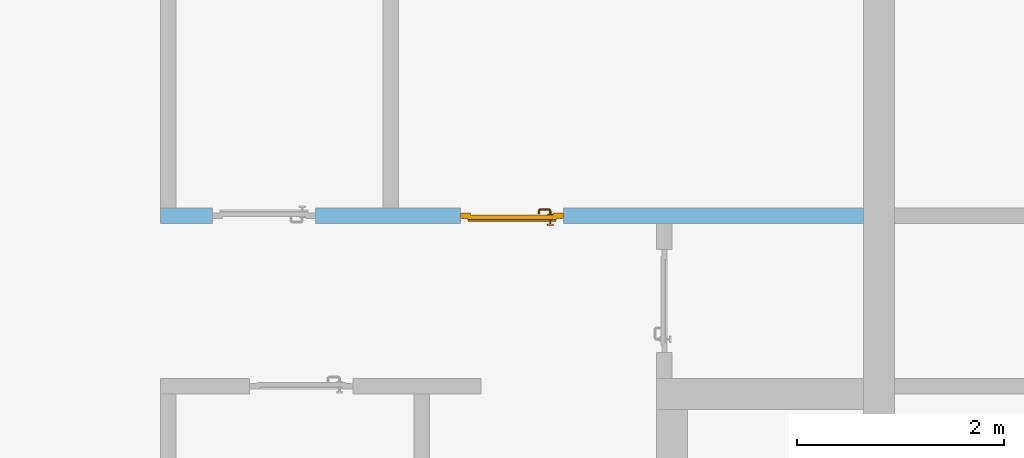
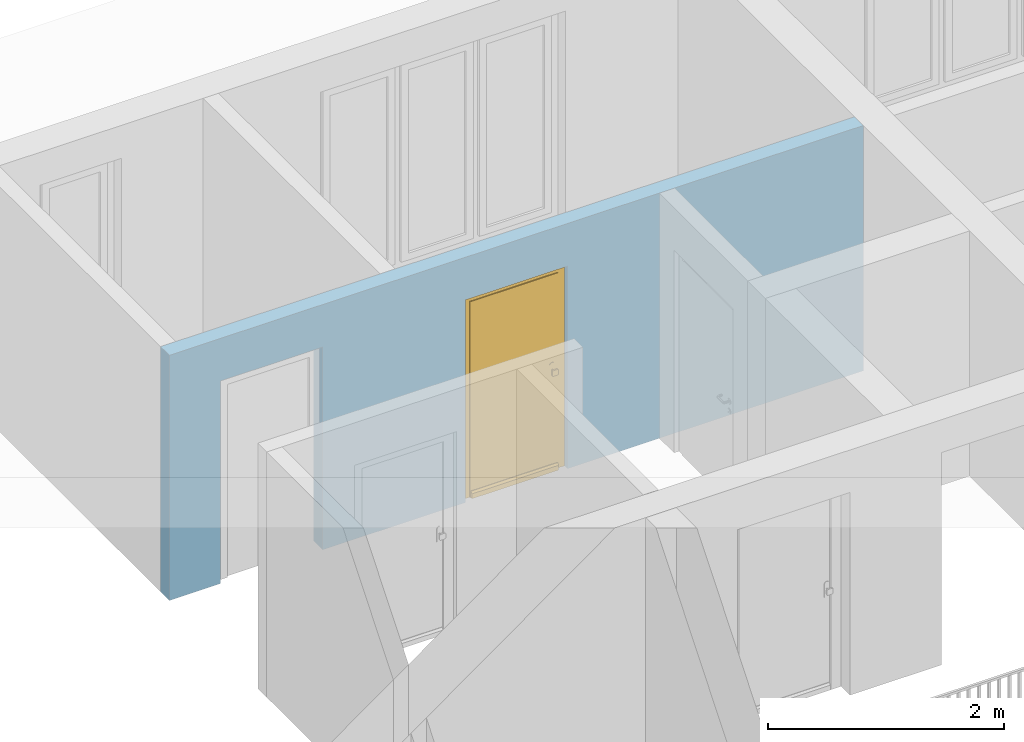
# One storey, part 26 of 54: 1 door, 2 openings, plus 1 element that does not belong to this part.
"""IFC4 building model written with IfcOpenShell, lengths in metres."""

from ifc_helpers import new_model, entity, si_unit, converted_unit, derived_unit, direction, frame, origin_with_axes, place, context, subcontext, project, spatial, polygons, source, transform, mapped, material, type_object, element, fill, save


model = new_model("IFC4")

# Units and contexts
model_context = context("Model", 3, precision=1e-05, world=origin_with_axes(), true_north=direction((0.0, 1.0)))
body_context = subcontext(model_context, "Body", "Model", "MODEL_VIEW")
ifc_project = project(units=[si_unit("LENGTHUNIT", "METRE"), si_unit("AREAUNIT", "SQUARE_METRE"), si_unit("VOLUMEUNIT", "CUBIC_METRE"), converted_unit("PLANEANGLEUNIT", "DEGREE", entity("IfcPlaneAngleMeasure", 0.0174532925199), si_unit("PLANEANGLEUNIT", "RADIAN"), dimensions=[0, 0, 0, 0, 0, 0, 0]), converted_unit("TIMEUNIT", "Year", entity("IfcTimeMeasure", 31556926.0), si_unit("TIMEUNIT", "SECOND"), dimensions=[0, 0, 1, 0, 0, 0, 0]), si_unit("MASSUNIT", "GRAM", prefix="KILO"), si_unit("THERMODYNAMICTEMPERATUREUNIT", "DEGREE_CELSIUS"), si_unit("LUMINOUSINTENSITYUNIT", "LUMEN"), si_unit("ENERGYUNIT", "JOULE", prefix="MEGA"), derived_unit("THERMALCONDUCTANCEUNIT", [(si_unit("POWERUNIT", "WATT"), 1), (si_unit("LENGTHUNIT", "METRE"), -1), (si_unit("THERMODYNAMICTEMPERATUREUNIT", "KELVIN"), -1)]), derived_unit("SPECIFICHEATCAPACITYUNIT", [(si_unit("ENERGYUNIT", "JOULE"), 1), (si_unit("MASSUNIT", "GRAM", prefix="KILO"), -1), (si_unit("THERMODYNAMICTEMPERATUREUNIT", "KELVIN"), -1)]), derived_unit("MASSDENSITYUNIT", [(si_unit("MASSUNIT", "GRAM", prefix="KILO"), 1), (si_unit("VOLUMEUNIT", "CUBIC_METRE"), -1)])], contexts=[model_context])

# Site, building, storey
site_placement = place(None, origin_with_axes())
site = spatial("IfcSite", under=ifc_project, at=site_placement, CompositionType="ELEMENT")
building_placement = place(site_placement, origin_with_axes())
building = spatial("IfcBuilding", under=site, at=building_placement, CompositionType="ELEMENT")
storey_placement = place(building_placement, frame((0.0, 0.0, 9.18), z_axis=(0.0, 0.0, 1.0), x_axis=(1.0, 0.0, 0.0)))
storey = spatial("IfcBuildingStorey", under=building, at=storey_placement, Name="3. Geschoss", CompositionType="ELEMENT", Elevation=9.18)

# Wall, openings, door
ifc_material = material()
wall_type = type_object("IfcWallType", Name="150", PredefinedType="NOTDEFINED")
wall_placement = place(storey_placement, frame((-7.5421993804, 5.47118776896, 0.0), z_axis=(0.0, 0.0, 1.0), x_axis=(1.0, 0.0, 0.0)))
wall = element("IfcWall", 1, at=wall_placement, inside=storey, type_object=wall_type, material=ifc_material, Name="Wand-002", PredefinedType="NOTDEFINED", context=body_context, shape_type="Tessellation", body=[
    polygons([(2.9, 0.15, 2.1), (2.9, 0.15, 0.0), (1.5, 0.15, 0.0), (1.5, 0.15, 2.1), (0.5, 0.15, 2.1), (0.5, 0.15, 0.0), (0.0, 0.15, 0.0), (0.0, 0.15, 2.54), (6.8, 0.15, 2.54), (6.8, 0.15, 0.0), (3.9, 0.15, 0.0), (3.9, 0.15, 2.1), (2.9, 0.05, 2.1), (2.9, 0.05, 0.0), (2.9, 0.0, 0.0), (1.5, 0.0, 0.0), (1.5, 0.1, 0.0), (1.5, 0.1, 2.1), (0.5, 0.1, 2.1), (0.5, 0.1, 0.0), (0.5, 0.0, 0.0), (0.0, 0.0, 0.0), (0.0, 0.0, 2.54), (6.8, 0.0, 2.54), (6.8, 0.0, 0.0), (3.9, 0.05, 0.0), (3.9, 0.0, 0.0), (3.9, 0.05, 2.1), (2.9, 0.0, 2.1), (3.9, 0.0, 2.1), (0.5, 0.0, 2.1), (1.5, 0.0, 2.1)], [[[1, 2, 3, 4, 5, 6, 7, 8, 9, 10, 11, 12]], [[2, 1, 13, 14]], [[2, 14, 15, 16, 17, 3]], [[4, 3, 17, 18]], [[5, 4, 18, 19]], [[6, 5, 19, 20]], [[6, 20, 21, 22, 7]], [[22, 23, 8, 7]], [[23, 24, 9, 8]], [[10, 9, 24, 25]], [[26, 11, 10, 25, 27]], [[12, 11, 26, 28]], [[1, 12, 28, 13]], [[14, 13, 29, 15]], [[16, 15, 29, 30, 27, 25, 24, 23, 22, 21, 31, 32]], [[16, 32, 18, 17]], [[32, 31, 19, 18]], [[31, 21, 20, 19]], [[28, 26, 27, 30]], [[13, 28, 30, 29]]], closed=True),
])
opening_1_placement = place(wall_placement, frame((1.0, 0.0, 0.0), z_axis=(0.0, 0.0, 1.0), x_axis=(1.0, 0.0, 0.0)))
element("IfcOpeningElement", 2, at=opening_1_placement, cuts=wall, context=body_context, identifier="Reference", shape_type="Tessellation", body=[
    polygons([(-0.5, 0.1, 0.0), (-0.5, 0.1, 2.1), (-0.5, 0.151, 2.1), (-0.5, 0.151, 0.0), (-0.5, -0.001, 0.0), (-0.5, -0.001, 2.1), (0.5, 0.1, 2.1), (0.5, 0.151, 2.1), (0.5, -0.001, 2.1), (0.5, 0.151, 0.0), (0.5, 0.1, 0.0), (0.5, -0.001, 0.0)], [[[1, 2, 3, 4]], [[2, 1, 5, 6]], [[7, 8, 3, 2, 6, 9]], [[8, 10, 4, 3]], [[1, 4, 10, 11, 12, 5]], [[6, 5, 12, 9]], [[7, 11, 10, 8]], [[11, 7, 9, 12]]], closed=True),
])
opening_2_placement = place(wall_placement, frame((3.4, 0.0, 0.0), z_axis=(0.0, 0.0, 1.0), x_axis=(1.0, 0.0, 0.0)))
opening_2 = element("IfcOpeningElement", 3, at=opening_2_placement, cuts=wall, context=body_context, identifier="Reference", shape_type="Tessellation", body=[
    polygons([(0.5, 0.05, 0.0), (0.5, 0.05, 2.1), (0.5, -0.001, 2.1), (0.5, -0.001, 0.0), (0.5, 0.151, 0.0), (0.5, 0.151, 2.1), (-0.5, 0.05, 2.1), (-0.5, -0.001, 2.1), (-0.5, 0.151, 2.1), (-0.5, -0.001, 0.0), (-0.5, 0.05, 0.0), (-0.5, 0.151, 0.0)], [[[1, 2, 3, 4]], [[2, 1, 5, 6]], [[7, 8, 3, 2, 6, 9]], [[8, 10, 4, 3]], [[1, 4, 10, 11, 12, 5]], [[6, 5, 12, 9]], [[7, 11, 10, 8]], [[11, 7, 9, 12]]], closed=True),
])
door_type = type_object("IfcDoorType", Name="Eingang 01 1-Fl 26", OperationType="SINGLE_SWING_RIGHT", PredefinedType="DOOR")
shared_shape = source(origin_with_axes(), body_context, "Body", "Tessellation", [
    polygons([(0.5, -0.05, 0.0), (0.5, -0.03, 0.0), (0.5, -0.03, 2.1), (0.5, -0.05, 2.1), (0.4, -0.05, 0.0), (0.4, -0.03, 0.0), (0.4, -0.03, 2.0), (0.1301, -0.03, 2.0), (0.0001, -0.03, 2.0), (-0.4, -0.03, 2.0), (-0.4, -0.03, 0.0), (-0.5, -0.03, 0.0), (-0.5, -0.03, 2.1), (-0.5, -0.05, 2.1), (-0.5, -0.05, 0.0), (-0.4, -0.05, 0.0), (-0.4, -0.05, 2.0), (0.0001, -0.05, 2.0), (0.1301, -0.05, 2.0), (0.4, -0.05, 2.0)], [[[1, 2, 3, 4]], [[5, 6, 2, 1]], [[2, 6, 7, 8, 9, 10, 11, 12, 13, 3]], [[4, 3, 13, 14]], [[1, 4, 14, 15, 16, 17, 18, 19, 20, 5]], [[20, 7, 6, 5]], [[19, 8, 7, 20]], [[18, 9, 8, 19]], [[17, 10, 9, 18]], [[16, 11, 10, 17]], [[15, 12, 11, 16]], [[14, 13, 12, 15]]], closed=True),
    polygons([(0.5, -0.03, 0.0), (0.5, 0.0, 0.0), (0.5, 0.0, 2.1), (0.5, -0.03, 2.1), (0.43, -0.03, 0.0), (0.43, 0.0, 0.0), (0.43, 0.0, 2.03), (0.1001, 0.0, 2.03), (0.0301, 0.0, 2.03), (-0.43, 0.0, 2.03), (-0.43, 0.0, 0.0), (-0.5, 0.0, 0.0), (-0.5, 0.0, 2.1), (-0.5, -0.03, 2.1), (-0.5, -0.03, 0.0), (-0.43, -0.03, 0.0), (-0.43, -0.03, 2.03), (0.0301, -0.03, 2.03), (0.1001, -0.03, 2.03), (0.43, -0.03, 2.03)], [[[1, 2, 3, 4]], [[5, 6, 2, 1]], [[2, 6, 7, 8, 9, 10, 11, 12, 13, 3]], [[4, 3, 13, 14]], [[1, 4, 14, 15, 16, 17, 18, 19, 20, 5]], [[20, 7, 6, 5]], [[19, 8, 7, 20]], [[18, 9, 8, 19]], [[17, 10, 9, 18]], [[16, 11, 10, 17]], [[15, 12, 11, 16]], [[14, 13, 12, 15]]], closed=True),
    polygons([(0.43, 0.01, 0.0), (-0.43, 0.01, 0.0), (-0.43, 0.01, 2.03), (0.43, 0.01, 2.03), (0.43, -0.03, 0.0), (-0.43, -0.03, 0.0), (-0.43, -0.03, 2.03), (0.43, -0.03, 2.03)], [[[1, 2, 3, 4]], [[2, 1, 5, 6]], [[3, 2, 6, 7]], [[4, 3, 7, 8]], [[1, 4, 8, 5]], [[6, 5, 8, 7]]], closed=True),
    polygons([(0.425, 0.03, 0.0), (-0.425, 0.03, 0.0), (-0.425, 0.03, 0.05), (0.425, 0.03, 0.05), (0.425, 0.01, 0.0), (-0.425, 0.01, 0.0), (-0.425, 0.01, 0.07), (-0.425, 0.015, 0.07), (0.425, 0.015, 0.07), (0.425, 0.01, 0.07)], [[[1, 2, 3, 4]], [[5, 6, 2, 1]], [[2, 6, 7, 8, 3]], [[4, 3, 8, 9]], [[1, 4, 9, 10, 5]], [[10, 7, 6, 5]], [[9, 8, 7, 10]]], closed=True),
    polygons([(-0.3835, -0.04, 1.0733826859), (-0.37, -0.04, 1.077), (-0.37, -0.0399, 1.077), (-0.3835, -0.0399, 1.0733826859), (-0.393382685902, -0.04, 1.0635), (-0.397, -0.04, 1.05), (-0.393382685902, -0.04, 1.0365), (-0.3835, -0.04, 1.0266173141), (-0.37, -0.04, 1.023), (-0.3565, -0.04, 1.0266173141), (-0.346617314098, -0.04, 1.0365), (-0.343, -0.04, 1.05), (-0.346617314098, -0.04, 1.0635), (-0.3565, -0.04, 1.0733826859), (-0.3565, -0.0399, 1.0733826859), (-0.37, -0.0301, 1.077), (-0.3835, -0.0301, 1.0733826859), (-0.393382685902, -0.0399, 1.0635), (-0.397, -0.0399, 1.05), (-0.393382685902, -0.0399, 1.0365), (-0.3835, -0.0399, 1.0266173141), (-0.37, -0.0399, 1.023), (-0.3565, -0.0399, 1.0266173141), (-0.346617314098, -0.0399, 1.0365), (-0.343, -0.0399, 1.05), (-0.346617314098, -0.0399, 1.0635), (-0.3565, -0.0301, 1.0733826859), (-0.37, -0.03, 1.077), (-0.3835, -0.03, 1.0733826859), (-0.393382685902, -0.0301, 1.0635), (-0.397, -0.0301, 1.05), (-0.393382685902, -0.0301, 1.0365), (-0.3835, -0.0301, 1.0266173141), (-0.37, -0.0301, 1.023), (-0.3565, -0.0301, 1.0266173141), (-0.346617314098, -0.0301, 1.0365), (-0.343, -0.0301, 1.05), (-0.346617314098, -0.0301, 1.0635), (-0.3565, -0.03, 1.0733826859), (-0.346617314098, -0.03, 1.0635), (-0.343, -0.03, 1.05), (-0.346617314098, -0.03, 1.0365), (-0.3565, -0.03, 1.0266173141), (-0.37, -0.03, 1.023), (-0.3835, -0.03, 1.0266173141), (-0.393382685902, -0.03, 1.0365), (-0.397, -0.03, 1.05), (-0.393382685902, -0.03, 1.0635)], [[[1, 2, 3, 4]], [[2, 1, 5, 6, 7, 8, 9, 10, 11, 12, 13, 14]], [[2, 14, 15, 3]], [[4, 3, 16, 17]], [[5, 1, 4, 18]], [[6, 5, 18, 19]], [[7, 6, 19, 20]], [[8, 7, 20, 21]], [[9, 8, 21, 22]], [[10, 9, 22, 23]], [[11, 10, 23, 24]], [[12, 11, 24, 25]], [[13, 12, 25, 26]], [[14, 13, 26, 15]], [[3, 15, 27, 16]], [[17, 16, 28, 29]], [[18, 4, 17, 30]], [[19, 18, 30, 31]], [[20, 19, 31, 32]], [[21, 20, 32, 33]], [[22, 21, 33, 34]], [[23, 22, 34, 35]], [[24, 23, 35, 36]], [[25, 24, 36, 37]], [[26, 25, 37, 38]], [[15, 26, 38, 27]], [[16, 27, 39, 28]], [[28, 39, 40, 41, 42, 43, 44, 45, 46, 47, 48, 29]], [[30, 17, 29, 48]], [[31, 30, 48, 47]], [[32, 31, 47, 46]], [[33, 32, 46, 45]], [[34, 33, 45, 44]], [[35, 34, 44, 43]], [[36, 35, 43, 42]], [[37, 36, 42, 41]], [[38, 37, 41, 40]], [[27, 38, 40, 39]]], closed=True),
    polygons([(-0.362532169224, -0.04, 0.959692280177), (-0.365, -0.04, 0.9544), (-0.365, -0.04, 0.952886751346), (-0.346703916638, -0.04, 0.96345), (-0.35655, -0.04, 0.973296083362), (-0.363279754556, -0.04, 0.961639806549), (-0.362532169224, -0.039, 0.959692280177), (-0.365, -0.039, 0.9544), (-0.365, -0.039, 0.952886751346), (-0.365, -0.039, 0.95), (-0.365, -0.039, 0.947113248654), (-0.365, -0.039, 0.941339745962), (-0.365, -0.039, 0.9375), (-0.365, -0.04, 0.9375), (-0.365, -0.04, 0.941339745962), (-0.365, -0.04, 0.947113248654), (-0.365, -0.04, 0.95), (-0.3431, -0.04, 0.95), (-0.346617314098, -0.04, 0.9635), (-0.3565, -0.04, 0.973382685902), (-0.364624817685, -0.04, 0.965143815798), (-0.37, -0.04, 0.9769), (-0.37, -0.04, 0.967425445323), (-0.364624817685, -0.039, 0.965143815798), (-0.363279754556, -0.039, 0.961639806549), (-0.35705, -0.039, 0.972430057958), (-0.347569942042, -0.039, 0.96295), (-0.3441, -0.039, 0.95), (-0.347569942042, -0.039, 0.93705), (-0.35705, -0.039, 0.927569942042), (-0.37, -0.039, 0.9241), (-0.37, -0.039, 0.9325), (-0.366464466094, -0.039, 0.933964466094), (-0.366464466094, -0.04, 0.933964466094), (-0.35655, -0.04, 0.926703916638), (-0.37, -0.04, 0.9325), (-0.37, -0.04, 0.9231), (-0.346703916638, -0.04, 0.93655), (-0.343, -0.04, 0.95), (-0.346617314098, -0.0399, 0.9635), (-0.3565, -0.0399, 0.973382685902), (-0.37, -0.04, 0.977), (-0.375375182315, -0.04, 0.965143815798), (-0.38345, -0.04, 0.973296083362), (-0.376720245444, -0.04, 0.961639806549), (-0.37, -0.039, 0.967425445323), (-0.37, -0.039, 0.9759), (-0.357, -0.039, 0.972516660498), (-0.347483339502, -0.039, 0.963), (-0.344, -0.039, 0.95), (-0.347483339502, -0.039, 0.937), (-0.357, -0.039, 0.927483339502), (-0.38295, -0.039, 0.927569942042), (-0.375, -0.039, 0.941339745962), (-0.375, -0.039, 0.9375), (-0.373535533906, -0.039, 0.933964466094), (-0.37, -0.039, 0.924), (-0.373535533906, -0.04, 0.933964466094), (-0.375, -0.04, 0.9375), (-0.375, -0.04, 0.941339745962), (-0.38345, -0.04, 0.926703916638), (-0.37, -0.04, 0.923), (-0.3565, -0.04, 0.926617314098), (-0.346617314098, -0.04, 0.9365), (-0.343, -0.0399, 0.95), (-0.346617314098, -0.0301, 0.9635), (-0.3565, -0.0301, 0.973382685902), (-0.37, -0.0399, 0.977), (-0.3835, -0.04, 0.973382685902), (-0.375375182315, -0.039, 0.965143815798), (-0.377467830776, -0.04, 0.959692280177), (-0.393296083362, -0.04, 0.96345), (-0.375, -0.04, 0.952886751346), (-0.375, -0.04, 0.9544), (-0.377467830776, -0.039, 0.959692280177), (-0.376720245444, -0.039, 0.961639806549), (-0.38295, -0.039, 0.972430057958), (-0.37, -0.039, 0.976), (-0.357, -0.0389, 0.972516660498), (-0.347483339502, -0.0389, 0.963), (-0.344, -0.0389, 0.95), (-0.347483339502, -0.0389, 0.937), (-0.357, -0.0389, 0.927483339502), (-0.392430057958, -0.039, 0.93705), (-0.375, -0.039, 0.947113248654), (-0.375, -0.039, 0.9544), (-0.375, -0.04, 0.95), (-0.375, -0.04, 0.947113248654), (-0.375, -0.039, 0.95), (-0.375, -0.039, 0.952886751346), (-0.383, -0.039, 0.927483339502), (-0.37, -0.0389, 0.924), (-0.393296083362, -0.04, 0.93655), (-0.3835, -0.04, 0.926617314098), (-0.37, -0.0399, 0.923), (-0.3565, -0.0399, 0.926617314098), (-0.346617314098, -0.0399, 0.9365), (-0.343, -0.0301, 0.95), (-0.346617314098, -0.03, 0.9635), (-0.3565, -0.03, 0.973382685902), (-0.37, -0.0301, 0.977), (-0.3835, -0.0399, 0.973382685902), (-0.393382685902, -0.04, 0.9635), (-0.3969, -0.04, 0.95), (-0.392430057958, -0.039, 0.96295), (-0.383, -0.039, 0.972516660498), (-0.37, -0.0389, 0.976), (-0.357, -0.0301, 0.972516660498), (-0.347483339502, -0.0301, 0.963), (-0.344, -0.0301, 0.95), (-0.347483339502, -0.0301, 0.937), (-0.357, -0.0301, 0.927483339502), (-0.392516660498, -0.039, 0.937), (-0.3959, -0.039, 0.95), (-0.383, -0.0389, 0.927483339502), (-0.37, -0.0301, 0.924), (-0.393382685902, -0.04, 0.9365), (-0.3835, -0.0399, 0.926617314098), (-0.37, -0.0301, 0.923), (-0.3565, -0.0301, 0.926617314098), (-0.346617314098, -0.0301, 0.9365), (-0.343, -0.03, 0.95), (-0.346703916638, -0.03, 0.96345), (-0.35655, -0.03, 0.973296083362), (-0.37, -0.03, 0.977), (-0.3835, -0.0301, 0.973382685902), (-0.393382685902, -0.0399, 0.9635), (-0.397, -0.04, 0.95), (-0.392516660498, -0.039, 0.963), (-0.383, -0.0389, 0.972516660498), (-0.37, -0.0301, 0.976), (-0.357, -0.03, 0.972516660498), (-0.347483339502, -0.03, 0.963), (-0.344, -0.03, 0.95), (-0.347483339502, -0.03, 0.937), (-0.357, -0.03, 0.927483339502), (-0.392516660498, -0.0389, 0.937), (-0.396, -0.039, 0.95), (-0.383, -0.0301, 0.927483339502), (-0.37, -0.03, 0.924), (-0.393382685902, -0.0399, 0.9365), (-0.3835, -0.0301, 0.926617314098), (-0.37, -0.03, 0.923), (-0.3565, -0.03, 0.926617314098), (-0.346617314098, -0.03, 0.9365), (-0.3431, -0.03, 0.95), (-0.347396736961, -0.03, 0.96305), (-0.35695, -0.03, 0.972603263039), (-0.37, -0.03, 0.9769), (-0.3835, -0.03, 0.973382685902), (-0.393382685902, -0.0301, 0.9635), (-0.397, -0.0399, 0.95), (-0.392516660498, -0.0389, 0.963), (-0.383, -0.0301, 0.972516660498), (-0.37, -0.03, 0.976), (-0.3439, -0.03, 0.95), (-0.347396736961, -0.03, 0.93695), (-0.35695, -0.03, 0.927396736961), (-0.392516660498, -0.0301, 0.937), (-0.396, -0.0389, 0.95), (-0.383, -0.03, 0.927483339502), (-0.37, -0.03, 0.9239), (-0.393382685902, -0.0301, 0.9365), (-0.3835, -0.03, 0.926617314098), (-0.37, -0.03, 0.9231), (-0.35655, -0.03, 0.926703916638), (-0.346703916638, -0.03, 0.93655), (-0.37, -0.03, 0.9761), (-0.38345, -0.03, 0.973296083362), (-0.393382685902, -0.03, 0.9635), (-0.397, -0.0301, 0.95), (-0.392516660498, -0.0301, 0.963), (-0.383, -0.03, 0.972516660498), (-0.392516660498, -0.03, 0.937), (-0.396, -0.0301, 0.95), (-0.38305, -0.03, 0.927396736961), (-0.393382685902, -0.03, 0.9365), (-0.38345, -0.03, 0.926703916638), (-0.38305, -0.03, 0.972603263039), (-0.393296083362, -0.03, 0.96345), (-0.397, -0.03, 0.95), (-0.392516660498, -0.03, 0.963), (-0.392603263039, -0.03, 0.93695), (-0.396, -0.03, 0.95), (-0.393296083362, -0.03, 0.93655), (-0.392603263039, -0.03, 0.96305), (-0.3969, -0.03, 0.95), (-0.3961, -0.03, 0.95)], [[[1, 2, 3, 4, 5, 6]], [[2, 1, 7, 8]], [[2, 8, 9, 10, 11, 12, 13, 14, 15, 16, 17, 3]], [[17, 18, 4, 3]], [[19, 20, 5, 4]], [[21, 6, 5, 22, 23]], [[1, 6, 21, 24, 25, 7]], [[7, 25, 26, 27, 9, 8]], [[9, 27, 28, 10]], [[10, 28, 29, 11]], [[11, 29, 30, 12]], [[31, 32, 33, 13, 12, 30]], [[14, 13, 33, 34]], [[35, 15, 14, 34, 36, 37]], [[15, 35, 38, 16]], [[16, 38, 18, 17]], [[39, 19, 4, 18]], [[40, 41, 20, 19]], [[20, 42, 22, 5]], [[43, 23, 22, 44, 45]], [[21, 23, 46, 24]], [[24, 46, 47, 26, 25]], [[27, 26, 48, 49]], [[28, 27, 49, 50]], [[29, 28, 50, 51]], [[30, 29, 51, 52]], [[53, 54, 55, 56, 32, 31]], [[34, 33, 32, 36]], [[31, 30, 52, 57]], [[37, 36, 58, 59, 60, 61]], [[62, 63, 35, 37]], [[63, 64, 38, 35]], [[64, 39, 18, 38]], [[65, 40, 19, 39]], [[66, 67, 41, 40]], [[41, 68, 42, 20]], [[42, 69, 44, 22]], [[23, 43, 70, 46]], [[71, 45, 44, 72, 73, 74]], [[43, 45, 71, 75, 76, 70]], [[70, 76, 77, 47, 46]], [[26, 47, 78, 48]], [[49, 48, 79, 80]], [[50, 49, 80, 81]], [[51, 50, 81, 82]], [[52, 51, 82, 83]], [[54, 53, 84, 85]], [[86, 74, 73, 87, 88, 60, 59, 55, 54, 85, 89, 90]], [[58, 56, 55, 59]], [[36, 32, 56, 58]], [[53, 31, 57, 91]], [[57, 52, 83, 92]], [[88, 93, 61, 60]], [[94, 62, 37, 61]], [[95, 96, 63, 62]], [[96, 97, 64, 63]], [[97, 65, 39, 64]], [[98, 66, 40, 65]], [[99, 100, 67, 66]], [[67, 101, 68, 41]], [[68, 102, 69, 42]], [[69, 103, 72, 44]], [[73, 72, 104, 87]], [[71, 74, 86, 75]], [[75, 86, 90, 105, 77, 76]], [[47, 77, 106, 78]], [[48, 78, 107, 79]], [[80, 79, 108, 109]], [[81, 80, 109, 110]], [[82, 81, 110, 111]], [[83, 82, 111, 112]], [[84, 53, 91, 113]], [[85, 84, 114, 89]], [[87, 104, 93, 88]], [[89, 114, 105, 90]], [[91, 57, 92, 115]], [[92, 83, 112, 116]], [[117, 94, 61, 93]], [[118, 95, 62, 94]], [[119, 120, 96, 95]], [[120, 121, 97, 96]], [[121, 98, 65, 97]], [[122, 99, 66, 98]], [[123, 124, 100, 99]], [[100, 125, 101, 67]], [[101, 126, 102, 68]], [[102, 127, 103, 69]], [[103, 128, 104, 72]], [[77, 105, 129, 106]], [[78, 106, 130, 107]], [[79, 107, 131, 108]], [[109, 108, 132, 133]], [[110, 109, 133, 134]], [[111, 110, 134, 135]], [[112, 111, 135, 136]], [[113, 91, 115, 137]], [[114, 84, 113, 138]], [[128, 117, 93, 104]], [[105, 114, 138, 129]], [[115, 92, 116, 139]], [[116, 112, 136, 140]], [[141, 118, 94, 117]], [[142, 119, 95, 118]], [[143, 144, 120, 119]], [[144, 145, 121, 120]], [[145, 122, 98, 121]], [[146, 123, 99, 122]], [[147, 148, 124, 123]], [[124, 149, 125, 100]], [[125, 150, 126, 101]], [[126, 151, 127, 102]], [[127, 152, 128, 103]], [[106, 129, 153, 130]], [[107, 130, 154, 131]], [[108, 131, 155, 132]], [[133, 132, 148, 147]], [[134, 133, 147, 156]], [[135, 134, 156, 157]], [[136, 135, 157, 158]], [[137, 115, 139, 159]], [[138, 113, 137, 160]], [[152, 141, 117, 128]], [[129, 138, 160, 153]], [[139, 116, 140, 161]], [[140, 136, 158, 162]], [[163, 142, 118, 141]], [[164, 143, 119, 142]], [[165, 166, 144, 143]], [[166, 167, 145, 144]], [[167, 146, 122, 145]], [[156, 147, 123, 146]], [[148, 168, 149, 124]], [[149, 169, 150, 125]], [[150, 170, 151, 126]], [[151, 171, 152, 127]], [[130, 153, 172, 154]], [[131, 154, 173, 155]], [[132, 155, 168, 148]], [[157, 156, 146, 167]], [[158, 157, 167, 166]], [[159, 139, 161, 174]], [[160, 137, 159, 175]], [[171, 163, 141, 152]], [[153, 160, 175, 172]], [[161, 140, 162, 176]], [[162, 158, 166, 165]], [[177, 164, 142, 163]], [[178, 165, 143, 164]], [[168, 179, 169, 149]], [[169, 180, 170, 150]], [[170, 181, 171, 151]], [[154, 172, 182, 173]], [[155, 173, 179, 168]], [[174, 161, 176, 183]], [[175, 159, 174, 184]], [[181, 177, 163, 171]], [[172, 175, 184, 182]], [[176, 162, 165, 178]], [[185, 178, 164, 177]], [[179, 186, 180, 169]], [[180, 187, 181, 170]], [[173, 182, 186, 179]], [[183, 176, 178, 185]], [[184, 174, 183, 188]], [[187, 185, 177, 181]], [[182, 184, 188, 186]], [[186, 188, 187, 180]], [[188, 183, 185, 187]]], closed=True),
    polygons([(-0.38, -0.04, 1.05), (-0.377071067812, -0.04, 1.04292893219), (-0.377071067812, -0.070696439392, 1.04292893219), (-0.38, -0.0709849140336, 1.05), (-0.37, -0.04, 1.04), (-0.37, -0.07, 1.04), (-0.375518993221, -0.0784992452783, 1.04292893219), (-0.378277987014, -0.0796420579258, 1.05), (-0.377071067812, -0.04, 1.05707106781), (-0.377071067812, -0.070696439392, 1.05707106781), (-0.362928932188, -0.04, 1.04292893219), (-0.362928932188, -0.069303560608, 1.04292893219), (-0.368858192988, -0.0757402514855, 1.04), (-0.370704557509, -0.0857045575088, 1.04292893219), (-0.372816199938, -0.0878161999379, 1.05), (-0.375518993221, -0.0784992452783, 1.05707106781), (-0.37, -0.04, 1.06), (-0.37, -0.07, 1.06), (-0.36, -0.04, 1.05), (-0.36, -0.0690150859664, 1.05), (-0.362197392755, -0.0729812576926, 1.04292893219), (-0.365606601718, -0.0806066017178, 1.04), (-0.363499245278, -0.0905189932208, 1.04292893219), (-0.364642057926, -0.0932779870137, 1.05), (-0.370704557509, -0.0857045575088, 1.05707106781), (-0.368858192988, -0.0757402514855, 1.06), (-0.362928932188, -0.04, 1.05707106781), (-0.362928932188, -0.069303560608, 1.05707106781), (-0.359438398962, -0.0718384450452, 1.05), (-0.360508645927, -0.0755086459268, 1.04292893219), (-0.360740251485, -0.0838581929877, 1.04), (-0.355696439392, -0.0920710678119, 1.04292893219), (-0.355984914034, -0.095, 1.05), (-0.363499245278, -0.0905189932208, 1.05707106781), (-0.365606601718, -0.0806066017178, 1.06), (-0.362197392755, -0.0729812576926, 1.05707106781), (-0.358397003498, -0.0733970034977, 1.05), (-0.357981257693, -0.0771973927545, 1.04292893219), (-0.355, -0.085, 1.04), (-0.274303560608, -0.0920710678119, 1.04292893219), (-0.274015085966, -0.095, 1.05), (-0.355696439392, -0.0920710678119, 1.05707106781), (-0.360740251485, -0.0838581929877, 1.06), (-0.360508645927, -0.0755086459268, 1.05707106781), (-0.356838445045, -0.0744383989617, 1.05), (-0.354303560608, -0.0779289321881, 1.04292893219), (-0.275, -0.085, 1.04), (-0.266500754722, -0.0905189932208, 1.04292893219), (-0.265357942074, -0.0932779870137, 1.05), (-0.274303560608, -0.0920710678119, 1.05707106781), (-0.355, -0.085, 1.06), (-0.357981257693, -0.0771973927545, 1.05707106781), (-0.354015085966, -0.075, 1.05), (-0.275696439392, -0.0779289321881, 1.04292893219), (-0.269259748515, -0.0838581929877, 1.04), (-0.259295442491, -0.0857045575088, 1.04292893219), (-0.257183800062, -0.0878161999379, 1.05), (-0.266500754722, -0.0905189932208, 1.05707106781), (-0.275, -0.085, 1.06), (-0.354303560608, -0.0779289321881, 1.05707106781), (-0.275984914034, -0.075, 1.05), (-0.272018742307, -0.0771973927545, 1.04292893219), (-0.264393398282, -0.0806066017178, 1.04), (-0.254481006779, -0.0784992452783, 1.04292893219), (-0.251722012986, -0.0796420579258, 1.05), (-0.259295442491, -0.0857045575088, 1.05707106781), (-0.269259748515, -0.0838581929877, 1.06), (-0.275696439392, -0.0779289321881, 1.05707106781), (-0.273161554955, -0.0744383989617, 1.05), (-0.269491354073, -0.0755086459268, 1.04292893219), (-0.261141807012, -0.0757402514855, 1.04), (-0.252928932188, -0.070696439392, 1.04292893219), (-0.25, -0.0709849140336, 1.05), (-0.254481006779, -0.0784992452783, 1.05707106781), (-0.264393398282, -0.0806066017178, 1.06), (-0.272018742307, -0.0771973927545, 1.05707106781), (-0.271602996502, -0.0733970034977, 1.05), (-0.267802607245, -0.0729812576926, 1.04292893219), (-0.26, -0.07, 1.04), (-0.252928932188, -0.04, 1.04292893219), (-0.25, -0.04, 1.05), (-0.252928932188, -0.070696439392, 1.05707106781), (-0.261141807012, -0.0757402514855, 1.06), (-0.269491354073, -0.0755086459268, 1.05707106781), (-0.270561601038, -0.0718384450452, 1.05), (-0.267071067812, -0.069303560608, 1.04292893219), (-0.26, -0.04, 1.04), (-0.267071067812, -0.04, 1.04292893219), (-0.27, -0.04, 1.05), (-0.267071067812, -0.04, 1.05707106781), (-0.26, -0.04, 1.06), (-0.252928932188, -0.04, 1.05707106781), (-0.26, -0.07, 1.06), (-0.267802607245, -0.0729812576926, 1.05707106781), (-0.27, -0.0690150859664, 1.05), (-0.267071067812, -0.069303560608, 1.05707106781)], [[[1, 2, 3, 4]], [[2, 5, 6, 3]], [[4, 3, 7, 8]], [[9, 1, 4, 10]], [[5, 11, 12, 6]], [[3, 6, 13, 7]], [[8, 7, 14, 15]], [[10, 4, 8, 16]], [[17, 9, 10, 18]], [[11, 19, 20, 12]], [[6, 12, 21, 13]], [[7, 13, 22, 14]], [[15, 14, 23, 24]], [[16, 8, 15, 25]], [[18, 10, 16, 26]], [[27, 17, 18, 28]], [[19, 27, 28, 20]], [[12, 20, 29, 21]], [[13, 21, 30, 22]], [[14, 22, 31, 23]], [[24, 23, 32, 33]], [[25, 15, 24, 34]], [[26, 16, 25, 35]], [[28, 18, 26, 36]], [[20, 28, 36, 29]], [[21, 29, 37, 30]], [[22, 30, 38, 31]], [[23, 31, 39, 32]], [[33, 32, 40, 41]], [[34, 24, 33, 42]], [[35, 25, 34, 43]], [[36, 26, 35, 44]], [[29, 36, 44, 37]], [[30, 37, 45, 38]], [[31, 38, 46, 39]], [[32, 39, 47, 40]], [[41, 40, 48, 49]], [[42, 33, 41, 50]], [[43, 34, 42, 51]], [[44, 35, 43, 52]], [[37, 44, 52, 45]], [[38, 45, 53, 46]], [[39, 46, 54, 47]], [[40, 47, 55, 48]], [[49, 48, 56, 57]], [[50, 41, 49, 58]], [[51, 42, 50, 59]], [[52, 43, 51, 60]], [[45, 52, 60, 53]], [[46, 53, 61, 54]], [[47, 54, 62, 55]], [[48, 55, 63, 56]], [[57, 56, 64, 65]], [[58, 49, 57, 66]], [[59, 50, 58, 67]], [[60, 51, 59, 68]], [[53, 60, 68, 61]], [[54, 61, 69, 62]], [[55, 62, 70, 63]], [[56, 63, 71, 64]], [[65, 64, 72, 73]], [[66, 57, 65, 74]], [[67, 58, 66, 75]], [[68, 59, 67, 76]], [[61, 68, 76, 69]], [[62, 69, 77, 70]], [[63, 70, 78, 71]], [[64, 71, 79, 72]], [[73, 72, 80, 81]], [[74, 65, 73, 82]], [[75, 66, 74, 83]], [[76, 67, 75, 84]], [[69, 76, 84, 77]], [[70, 77, 85, 78]], [[71, 78, 86, 79]], [[72, 79, 87, 80]], [[81, 80, 87, 88, 89, 90, 91, 92]], [[82, 73, 81, 92]], [[83, 74, 82, 93]], [[84, 75, 83, 94]], [[77, 84, 94, 85]], [[78, 85, 95, 86]], [[79, 86, 88, 87]], [[86, 95, 89, 88]], [[95, 96, 90, 89]], [[96, 93, 91, 90]], [[93, 82, 92, 91]], [[94, 83, 93, 96]], [[85, 94, 96, 95]]], closed=False),
    polygons([(-0.364696699141, 0.015, 1.04469669914), (-0.3625, 0.015, 1.05), (-0.364696699141, 0.015, 1.05530330086), (-0.37, 0.015, 1.0575), (-0.375303300859, 0.015, 1.05530330086), (-0.3775, 0.015, 1.05), (-0.375303300859, 0.015, 1.04469669914), (-0.37, 0.015, 1.0425), (-0.364696699141, 0.055, 1.04469669914), (-0.3625, 0.055, 1.05), (-0.364696699141, 0.055, 1.05530330086), (-0.37, 0.055, 1.0575), (-0.375303300859, 0.055, 1.05530330086), (-0.3775, 0.055, 1.05), (-0.375303300859, 0.055, 1.04469669914), (-0.37, 0.055, 1.0425)], [[[1, 2, 3, 4, 5, 6, 7, 8]], [[1, 9, 10, 2]], [[2, 10, 11, 3]], [[3, 11, 12, 4]], [[4, 12, 13, 5]], [[5, 13, 14, 6]], [[6, 14, 15, 7]], [[7, 15, 16, 8]], [[8, 16, 9, 1]], [[9, 16, 15, 14, 13, 12, 11, 10]]], closed=True),
    polygons([(-0.395, 0.01, 0.975), (-0.395, 0.015, 0.975), (-0.393096988313, 0.015, 0.965432914191), (-0.393096988313, 0.01, 0.965432914191), (-0.395, 0.01, 1.1), (-0.395, 0.015, 1.1), (-0.393096988313, 0.015, 1.10956708581), (-0.38767766953, 0.015, 1.11767766953), (-0.379567085809, 0.015, 1.12309698831), (-0.37, 0.015, 1.125), (-0.360432914191, 0.015, 1.12309698831), (-0.35232233047, 0.015, 1.11767766953), (-0.346903011687, 0.015, 1.10956708581), (-0.345, 0.015, 1.1), (-0.345, 0.015, 0.975), (-0.346903011687, 0.015, 0.965432914191), (-0.35232233047, 0.015, 0.95732233047), (-0.360432914191, 0.015, 0.951903011687), (-0.37, 0.015, 0.95), (-0.379567085809, 0.015, 0.951903011687), (-0.38767766953, 0.015, 0.95732233047), (-0.38767766953, 0.01, 0.95732233047), (-0.379567085809, 0.01, 0.951903011687), (-0.37, 0.01, 0.95), (-0.360432914191, 0.01, 0.951903011687), (-0.35232233047, 0.01, 0.95732233047), (-0.346903011687, 0.01, 0.965432914191), (-0.345, 0.01, 0.975), (-0.345, 0.01, 1.1), (-0.346903011687, 0.01, 1.10956708581), (-0.35232233047, 0.01, 1.11767766953), (-0.360432914191, 0.01, 1.12309698831), (-0.37, 0.01, 1.125), (-0.379567085809, 0.01, 1.12309698831), (-0.38767766953, 0.01, 1.11767766953), (-0.393096988313, 0.01, 1.10956708581)], [[[1, 2, 3, 4]], [[5, 6, 2, 1]], [[2, 6, 7, 8, 9, 10, 11, 12, 13, 14, 15, 16, 17, 18, 19, 20, 21, 3]], [[4, 3, 21, 22]], [[1, 4, 22, 23, 24, 25, 26, 27, 28, 29, 30, 31, 32, 33, 34, 35, 36, 5]], [[36, 7, 6, 5]], [[35, 8, 7, 36]], [[34, 9, 8, 35]], [[33, 10, 9, 34]], [[32, 11, 10, 33]], [[31, 12, 11, 32]], [[30, 13, 12, 31]], [[29, 14, 13, 30]], [[28, 15, 14, 29]], [[27, 16, 15, 28]], [[26, 17, 16, 27]], [[25, 18, 17, 26]], [[24, 19, 18, 25]], [[23, 20, 19, 24]], [[22, 21, 20, 23]]], closed=True),
    polygons([(-0.39, 0.055, 1.08), (-0.39, 0.07, 1.08), (-0.395, 0.07, 1.07866025404), (-0.395, 0.055, 1.07866025404), (-0.35, 0.055, 1.08), (-0.35, 0.07, 1.08), (-0.345, 0.07, 1.07866025404), (-0.341339745962, 0.07, 1.075), (-0.34, 0.07, 1.07), (-0.34, 0.07, 1.03), (-0.341339745962, 0.07, 1.025), (-0.345, 0.07, 1.02133974596), (-0.35, 0.07, 1.02), (-0.39, 0.07, 1.02), (-0.395, 0.07, 1.02133974596), (-0.398660254038, 0.07, 1.025), (-0.4, 0.07, 1.03), (-0.4, 0.07, 1.07), (-0.398660254038, 0.07, 1.075), (-0.398660254038, 0.055, 1.075), (-0.4, 0.055, 1.07), (-0.4, 0.055, 1.03), (-0.398660254038, 0.055, 1.025), (-0.395, 0.055, 1.02133974596), (-0.39, 0.055, 1.02), (-0.35, 0.055, 1.02), (-0.345, 0.055, 1.02133974596), (-0.341339745962, 0.055, 1.025), (-0.34, 0.055, 1.03), (-0.34, 0.055, 1.07), (-0.341339745962, 0.055, 1.075), (-0.345, 0.055, 1.07866025404)], [[[1, 2, 3, 4]], [[5, 6, 2, 1]], [[2, 6, 7, 8, 9, 10, 11, 12, 13, 14, 15, 16, 17, 18, 19, 3]], [[4, 3, 19, 20]], [[1, 4, 20, 21, 22, 23, 24, 25, 26, 27, 28, 29, 30, 31, 32, 5]], [[32, 7, 6, 5]], [[31, 8, 7, 32]], [[30, 9, 8, 31]], [[29, 10, 9, 30]], [[28, 11, 10, 29]], [[27, 12, 11, 28]], [[26, 13, 12, 27]], [[25, 14, 13, 26]], [[24, 15, 14, 25]], [[23, 16, 15, 24]], [[22, 17, 16, 23]], [[21, 18, 17, 22]], [[20, 19, 18, 21]]], closed=True),
])
door_placement = place(opening_2_placement, frame((0.4, 0.0, 0.0), z_axis=(0.0, 0.0, 1.0), x_axis=(-1.0, 0.0, 0.0)))
door = element("IfcDoor", 4, at=door_placement, inside=storey, type_object=door_type, OverallHeight=2.1, OverallWidth=1.0, PredefinedType="DOOR", context=body_context, shape_type="MappedRepresentation", body=[
    mapped(shared_shape, transform((0.4, -0.05, 0.0))),
])
fill(opening_2, door)

save(model, "model.ifc")
